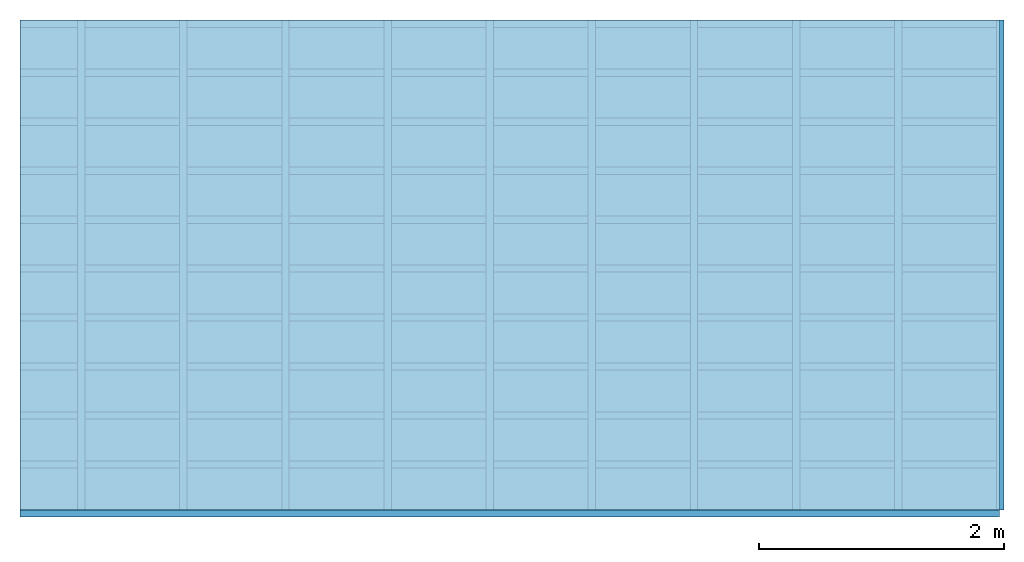
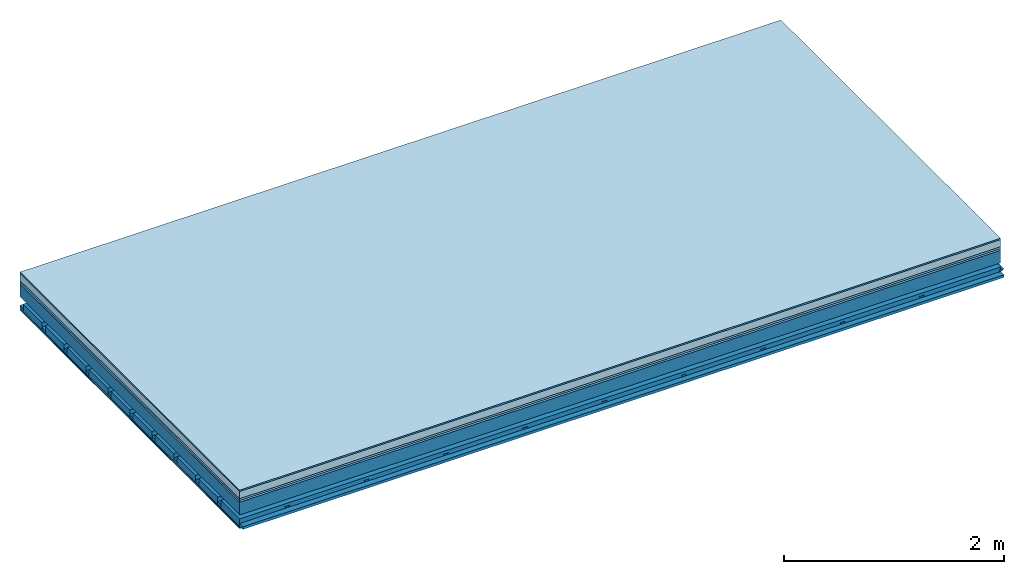
# One storey: 7 plates, 4 members, 1 element without a shape of its own.
"""IFC4 building model written with IfcOpenShell, lengths in metres."""

from ifc_helpers import new_model, si_unit, derived_unit, direction, frame, frame_2d, origin, origin_with_axes, place, context, project, spatial, polyline, rectangle, outline, extrude, material, layer, layer_set, type_object, element, aggregate, save


model = new_model("IFC4")

# Units and contexts
plan_context = context("Plan", 3, precision=1e-05, world=origin(), true_north=direction((0.0, 1.0)))
model_context = context("Model", 3, precision=1e-05, world=origin(), true_north=direction((0.0, 1.0)))
ifc_project = project(units=[si_unit("LENGTHUNIT", "METRE"), derived_unit("SOUNDPRESSUREUNIT", [(si_unit("PRESSUREUNIT", "PASCAL", prefix="MICRO"), 0)]), si_unit("ENERGYUNIT", "JOULE", prefix="MEGA"), si_unit("MASSUNIT", "GRAM", prefix="KILO"), derived_unit("THERMALTRANSMITTANCEUNIT", [(si_unit("POWERUNIT", "WATT"), 1), (si_unit("AREAUNIT", "SQUARE_METRE"), -1), (si_unit("THERMODYNAMICTEMPERATUREUNIT", "KELVIN"), -1)]), derived_unit("AREADENSITYUNIT", [(si_unit("MASSUNIT", "GRAM", prefix="KILO"), 1), (si_unit("AREAUNIT", "SQUARE_METRE"), -1)]), derived_unit("USERDEFINED", [(si_unit("ENERGYUNIT", "JOULE", prefix="MEGA"), 1), (si_unit("AREAUNIT", "SQUARE_METRE"), -1)])], contexts=[plan_context, model_context])

# Site, building, storey
site = spatial("IfcSite", under=ifc_project)
building_placement = place(None, origin())
building = spatial("IfcBuilding", under=site, at=building_placement)
storey_placement = place(building_placement, origin())
storey = spatial("IfcBuildingStorey", under=building, at=storey_placement)

# Slab, members, plates
ifc_material_1 = material(Category="11.013")
ifc_layer_1 = layer(ifc_material_1, 0.015, Name="Flooring")
ifc_material_2 = material(Name="Cement screed", Category="04.006")
ifc_layer_2 = layer(ifc_material_2, 0.08, Name="On-material")
ifc_material_3 = material(Name="Wood fiber generic product", Category="10.009")
ifc_layer_3 = layer(ifc_material_3, 0.02, Name="Impact sound insulation")
ifc_material_4 = material(Category="10.004")
ifc_layer_4 = layer(ifc_material_4, 0.02, Name="Additional insulation")
ifc_material_5 = material(Name="no composite action")
ifc_layer_5 = layer(ifc_material_5, 0.0, Name="Bond")
ifc_layer_6 = layer(None, 0.14, Name="Supporting structure")
ifc_layer_7 = layer(ifc_material_5, 0.0, Name="Bond")
ifc_layer_8 = layer(None, 0.095, Name="Coupling")
ifc_layer_9 = layer(None, 0.03, Name="Battens / profiles")
ifc_material_6 = material(Name="Plasterboard type A", Category="03.008")
ifc_layer_10 = layer(ifc_material_6, 0.0125, Name="Ceiling covering 1st layer")
ifc_layer_11 = layer(ifc_material_6, 0.0125, Name="Ceiling covering layer 2")
ifc_material_7 = material(Category="04.001")
ifc_layer_12 = layer(ifc_material_7, 0.003, Name="Surface / treatment")
ifc_layer_set = layer_set([ifc_layer_1, ifc_layer_2, ifc_layer_3, ifc_layer_4, ifc_layer_5, ifc_layer_6, ifc_layer_7, ifc_layer_8, ifc_layer_9, ifc_layer_10, ifc_layer_11, ifc_layer_12])
slab_type = type_object("IfcSlabType", Name="A2151", PredefinedType="NOTDEFINED", material=ifc_layer_set)
slab_placement = place(None, frame((0.0, 0.0, 0.0), z_axis=(0.0, 0.0, -1.0), x_axis=(1.0, 0.0, 0.0)))
slab = element("IfcSlab", 1, at=slab_placement, inside=storey, type_object=slab_type, material=ifc_layer_set, Name="Slab #1")
ifc_material_8 = material(Name="Solid timber panel")
member_1_placement = place(slab_placement, origin())
member_1 = element("IfcMember", 2, at=member_1_placement, material=ifc_material_8, Name="Supporting structure", context=plan_context, shape_type="SweptSolid", body=[
    extrude(rectangle(XDim=1.0, YDim=0.14, at=frame_2d((0.5, 0.07), x_axis=(1.0, 0.0))), frame((0.0, 4.0, 0.135), z_axis=(0.0, -1.0, 0.0), x_axis=(1.0, 0.0, 0.0)), (0.0, 0.0, 1.0), 4.0),
    extrude(rectangle(XDim=1.0, YDim=0.14, at=frame_2d((0.5, 0.07), x_axis=(1.0, 0.0))), frame((1.0, 4.0, 0.135), z_axis=(0.0, -1.0, 0.0), x_axis=(1.0, 0.0, 0.0)), (0.0, 0.0, 1.0), 4.0),
    extrude(rectangle(XDim=1.0, YDim=0.14, at=frame_2d((0.5, 0.07), x_axis=(1.0, 0.0))), frame((2.0, 4.0, 0.135), z_axis=(0.0, -1.0, 0.0), x_axis=(1.0, 0.0, 0.0)), (0.0, 0.0, 1.0), 4.0),
    extrude(rectangle(XDim=1.0, YDim=0.14, at=frame_2d((0.5, 0.07), x_axis=(1.0, 0.0))), frame((3.0, 4.0, 0.135), z_axis=(0.0, -1.0, 0.0), x_axis=(1.0, 0.0, 0.0)), (0.0, 0.0, 1.0), 4.0),
    extrude(rectangle(XDim=1.0, YDim=0.14, at=frame_2d((0.5, 0.07), x_axis=(1.0, 0.0))), frame((4.0, 4.0, 0.135), z_axis=(0.0, -1.0, 0.0), x_axis=(1.0, 0.0, 0.0)), (0.0, 0.0, 1.0), 4.0),
    extrude(rectangle(XDim=1.0, YDim=0.14, at=frame_2d((0.5, 0.07), x_axis=(1.0, 0.0))), frame((5.0, 4.0, 0.135), z_axis=(0.0, -1.0, 0.0), x_axis=(1.0, 0.0, 0.0)), (0.0, 0.0, 1.0), 4.0),
    extrude(rectangle(XDim=1.0, YDim=0.14, at=frame_2d((0.5, 0.07), x_axis=(1.0, 0.0))), frame((6.0, 4.0, 0.135), z_axis=(0.0, -1.0, 0.0), x_axis=(1.0, 0.0, 0.0)), (0.0, 0.0, 1.0), 4.0),
    extrude(rectangle(XDim=1.0, YDim=0.14, at=frame_2d((0.5, 0.07), x_axis=(1.0, 0.0))), frame((7.0, 4.0, 0.135), z_axis=(0.0, -1.0, 0.0), x_axis=(1.0, 0.0, 0.0)), (0.0, 0.0, 1.0), 4.0),
])
ifc_material_9 = material()
member_2_placement = place(slab_placement, origin())
member_2 = element("IfcMember", 3, at=member_2_placement, material=ifc_material_9, Name="Coupling", context=plan_context, shape_type="SweptSolid", body=[
    extrude(outline(polyline([(0.0, 0.0), (0.06, 0.0), (0.04, 0.02), (0.02, 0.02), (0.0, 0.0)])), frame((0.47, 4.0, 0.35), z_axis=(0.0, -1.0, 0.0), x_axis=(1.0, 0.0, 0.0)), (0.0, 0.0, 1.0), 4.0),
    extrude(outline(polyline([(0.0, 0.0), (0.06, 0.0), (0.04, 0.02), (0.02, 0.02), (0.0, 0.0)])), frame((1.304, 4.0, 0.35), z_axis=(0.0, -1.0, 0.0), x_axis=(1.0, 0.0, 0.0)), (0.0, 0.0, 1.0), 4.0),
    extrude(outline(polyline([(0.0, 0.0), (0.06, 0.0), (0.04, 0.02), (0.02, 0.02), (0.0, 0.0)])), frame((2.138, 4.0, 0.35), z_axis=(0.0, -1.0, 0.0), x_axis=(1.0, 0.0, 0.0)), (0.0, 0.0, 1.0), 4.0),
    extrude(outline(polyline([(0.0, 0.0), (0.06, 0.0), (0.04, 0.02), (0.02, 0.02), (0.0, 0.0)])), frame((2.972, 4.0, 0.35), z_axis=(0.0, -1.0, 0.0), x_axis=(1.0, 0.0, 0.0)), (0.0, 0.0, 1.0), 4.0),
    extrude(outline(polyline([(0.0, 0.0), (0.06, 0.0), (0.04, 0.02), (0.02, 0.02), (0.0, 0.0)])), frame((3.806, 4.0, 0.35), z_axis=(0.0, -1.0, 0.0), x_axis=(1.0, 0.0, 0.0)), (0.0, 0.0, 1.0), 4.0),
    extrude(outline(polyline([(0.0, 0.0), (0.06, 0.0), (0.04, 0.02), (0.02, 0.02), (0.0, 0.0)])), frame((4.64, 4.0, 0.35), z_axis=(0.0, -1.0, 0.0), x_axis=(1.0, 0.0, 0.0)), (0.0, 0.0, 1.0), 4.0),
    extrude(outline(polyline([(0.0, 0.0), (0.06, 0.0), (0.04, 0.02), (0.02, 0.02), (0.0, 0.0)])), frame((5.474, 4.0, 0.35), z_axis=(0.0, -1.0, 0.0), x_axis=(1.0, 0.0, 0.0)), (0.0, 0.0, 1.0), 4.0),
    extrude(outline(polyline([(0.0, 0.0), (0.06, 0.0), (0.04, 0.02), (0.02, 0.02), (0.0, 0.0)])), frame((6.308, 4.0, 0.35), z_axis=(0.0, -1.0, 0.0), x_axis=(1.0, 0.0, 0.0)), (0.0, 0.0, 1.0), 4.0),
    extrude(outline(polyline([(0.0, 0.0), (0.06, 0.0), (0.04, 0.02), (0.02, 0.02), (0.0, 0.0)])), frame((7.142, 4.0, 0.35), z_axis=(0.0, -1.0, 0.0), x_axis=(1.0, 0.0, 0.0)), (0.0, 0.0, 1.0), 4.0),
    extrude(outline(polyline([(0.0, 0.0), (0.06, 0.0), (0.04, 0.02), (0.02, 0.02), (0.0, 0.0)])), frame((7.976, 4.0, 0.35), z_axis=(0.0, -1.0, 0.0), x_axis=(1.0, 0.0, 0.0)), (0.0, 0.0, 1.0), 4.0),
])
member_3_placement = place(slab_placement, origin())
member_3 = element("IfcMember", 4, at=member_3_placement, material=ifc_material_9, Name="Battens / profiles", context=plan_context, shape_type="SweptSolid", body=[
    extrude(rectangle(XDim=0.06, YDim=0.03, at=frame_2d((0.03, 0.015), x_axis=(1.0, 0.0))), frame((0.0, 0.0, 0.37), z_axis=(1.0, 0.0, 0.0), x_axis=(0.0, 1.0, 0.0)), (0.0, 0.0, 1.0), 8.0),
    extrude(rectangle(XDim=0.06, YDim=0.03, at=frame_2d((0.03, 0.015), x_axis=(1.0, 0.0))), frame((0.0, 0.4, 0.37), z_axis=(1.0, 0.0, 0.0), x_axis=(0.0, 1.0, 0.0)), (0.0, 0.0, 1.0), 8.0),
    extrude(rectangle(XDim=0.06, YDim=0.03, at=frame_2d((0.03, 0.015), x_axis=(1.0, 0.0))), frame((0.0, 0.8, 0.37), z_axis=(1.0, 0.0, 0.0), x_axis=(0.0, 1.0, 0.0)), (0.0, 0.0, 1.0), 8.0),
    extrude(rectangle(XDim=0.06, YDim=0.03, at=frame_2d((0.03, 0.015), x_axis=(1.0, 0.0))), frame((0.0, 1.2, 0.37), z_axis=(1.0, 0.0, 0.0), x_axis=(0.0, 1.0, 0.0)), (0.0, 0.0, 1.0), 8.0),
    extrude(rectangle(XDim=0.06, YDim=0.03, at=frame_2d((0.03, 0.015), x_axis=(1.0, 0.0))), frame((0.0, 1.6, 0.37), z_axis=(1.0, 0.0, 0.0), x_axis=(0.0, 1.0, 0.0)), (0.0, 0.0, 1.0), 8.0),
    extrude(rectangle(XDim=0.06, YDim=0.03, at=frame_2d((0.03, 0.015), x_axis=(1.0, 0.0))), frame((0.0, 2.0, 0.37), z_axis=(1.0, 0.0, 0.0), x_axis=(0.0, 1.0, 0.0)), (0.0, 0.0, 1.0), 8.0),
    extrude(rectangle(XDim=0.06, YDim=0.03, at=frame_2d((0.03, 0.015), x_axis=(1.0, 0.0))), frame((0.0, 2.4, 0.37), z_axis=(1.0, 0.0, 0.0), x_axis=(0.0, 1.0, 0.0)), (0.0, 0.0, 1.0), 8.0),
    extrude(rectangle(XDim=0.06, YDim=0.03, at=frame_2d((0.03, 0.015), x_axis=(1.0, 0.0))), frame((0.0, 2.8, 0.37), z_axis=(1.0, 0.0, 0.0), x_axis=(0.0, 1.0, 0.0)), (0.0, 0.0, 1.0), 8.0),
    extrude(rectangle(XDim=0.06, YDim=0.03, at=frame_2d((0.03, 0.015), x_axis=(1.0, 0.0))), frame((0.0, 3.2, 0.37), z_axis=(1.0, 0.0, 0.0), x_axis=(0.0, 1.0, 0.0)), (0.0, 0.0, 1.0), 8.0),
    extrude(rectangle(XDim=0.06, YDim=0.03, at=frame_2d((0.03, 0.015), x_axis=(1.0, 0.0))), frame((0.0, 3.6, 0.37), z_axis=(1.0, 0.0, 0.0), x_axis=(0.0, 1.0, 0.0)), (0.0, 0.0, 1.0), 8.0),
    extrude(rectangle(XDim=0.06, YDim=0.03, at=frame_2d((0.03, 0.015), x_axis=(1.0, 0.0))), frame((0.0, 4.0, 0.37), z_axis=(1.0, 0.0, 0.0), x_axis=(0.0, 1.0, 0.0)), (0.0, 0.0, 1.0), 8.0),
])
ifc_material_10 = material()
member_4_placement = place(slab_placement, origin())
member_4 = element("IfcMember", 5, at=member_4_placement, material=ifc_material_10, Name="Cavity", context=plan_context, shape_type="SweptSolid", body=[
    extrude(rectangle(XDim=0.34, YDim=0.08, at=frame_2d((0.17, 0.04), x_axis=(1.0, 0.0))), frame((0.0, 0.06, 0.32), z_axis=(1.0, 0.0, 0.0), x_axis=(0.0, 1.0, 0.0)), (0.0, 0.0, 1.0), 8.0),
    extrude(rectangle(XDim=0.34, YDim=0.08, at=frame_2d((0.17, 0.04), x_axis=(1.0, 0.0))), frame((0.0, 0.46, 0.32), z_axis=(1.0, 0.0, 0.0), x_axis=(0.0, 1.0, 0.0)), (0.0, 0.0, 1.0), 8.0),
    extrude(rectangle(XDim=0.34, YDim=0.08, at=frame_2d((0.17, 0.04), x_axis=(1.0, 0.0))), frame((0.0, 0.86, 0.32), z_axis=(1.0, 0.0, 0.0), x_axis=(0.0, 1.0, 0.0)), (0.0, 0.0, 1.0), 8.0),
    extrude(rectangle(XDim=0.34, YDim=0.08, at=frame_2d((0.17, 0.04), x_axis=(1.0, 0.0))), frame((0.0, 1.26, 0.32), z_axis=(1.0, 0.0, 0.0), x_axis=(0.0, 1.0, 0.0)), (0.0, 0.0, 1.0), 8.0),
    extrude(rectangle(XDim=0.34, YDim=0.08, at=frame_2d((0.17, 0.04), x_axis=(1.0, 0.0))), frame((0.0, 1.66, 0.32), z_axis=(1.0, 0.0, 0.0), x_axis=(0.0, 1.0, 0.0)), (0.0, 0.0, 1.0), 8.0),
    extrude(rectangle(XDim=0.34, YDim=0.08, at=frame_2d((0.17, 0.04), x_axis=(1.0, 0.0))), frame((0.0, 2.06, 0.32), z_axis=(1.0, 0.0, 0.0), x_axis=(0.0, 1.0, 0.0)), (0.0, 0.0, 1.0), 8.0),
    extrude(rectangle(XDim=0.34, YDim=0.08, at=frame_2d((0.17, 0.04), x_axis=(1.0, 0.0))), frame((0.0, 2.46, 0.32), z_axis=(1.0, 0.0, 0.0), x_axis=(0.0, 1.0, 0.0)), (0.0, 0.0, 1.0), 8.0),
    extrude(rectangle(XDim=0.34, YDim=0.08, at=frame_2d((0.17, 0.04), x_axis=(1.0, 0.0))), frame((0.0, 2.86, 0.32), z_axis=(1.0, 0.0, 0.0), x_axis=(0.0, 1.0, 0.0)), (0.0, 0.0, 1.0), 8.0),
    extrude(rectangle(XDim=0.34, YDim=0.08, at=frame_2d((0.17, 0.04), x_axis=(1.0, 0.0))), frame((0.0, 3.26, 0.32), z_axis=(1.0, 0.0, 0.0), x_axis=(0.0, 1.0, 0.0)), (0.0, 0.0, 1.0), 8.0),
    extrude(rectangle(XDim=0.34, YDim=0.08, at=frame_2d((0.17, 0.04), x_axis=(1.0, 0.0))), frame((0.0, 3.66, 0.32), z_axis=(1.0, 0.0, 0.0), x_axis=(0.0, 1.0, 0.0)), (0.0, 0.0, 1.0), 8.0),
])
plate_1_placement = place(slab_placement, origin())
plate_1 = element("IfcPlate", 6, at=plate_1_placement, material=ifc_material_1, Name="Flooring", context=plan_context, shape_type="SweptSolid", body=[
    extrude(rectangle(XDim=8.0, YDim=4.0, at=frame_2d((4.0, 2.0), x_axis=(1.0, 0.0))), origin_with_axes(), (0.0, 0.0, 1.0), 0.015),
])
plate_2_placement = place(slab_placement, origin())
plate_2 = element("IfcPlate", 7, at=plate_2_placement, material=ifc_material_2, Name="On-material", context=plan_context, shape_type="SweptSolid", body=[
    extrude(rectangle(XDim=8.0, YDim=4.0, at=frame_2d((4.0, 2.0), x_axis=(1.0, 0.0))), frame((0.0, 0.0, 0.015), z_axis=(0.0, 0.0, 1.0), x_axis=(1.0, 0.0, 0.0)), (0.0, 0.0, 1.0), 0.08),
])
plate_3_placement = place(slab_placement, origin())
plate_3 = element("IfcPlate", 8, at=plate_3_placement, material=ifc_material_3, Name="Impact sound insulation", context=plan_context, shape_type="SweptSolid", body=[
    extrude(rectangle(XDim=8.0, YDim=4.0, at=frame_2d((4.0, 2.0), x_axis=(1.0, 0.0))), frame((0.0, 0.0, 0.095), z_axis=(0.0, 0.0, 1.0), x_axis=(1.0, 0.0, 0.0)), (0.0, 0.0, 1.0), 0.02),
])
plate_4_placement = place(slab_placement, origin())
plate_4 = element("IfcPlate", 9, at=plate_4_placement, material=ifc_material_4, Name="Additional insulation", context=plan_context, shape_type="SweptSolid", body=[
    extrude(rectangle(XDim=8.0, YDim=4.0, at=frame_2d((4.0, 2.0), x_axis=(1.0, 0.0))), frame((0.0, 0.0, 0.115), z_axis=(0.0, 0.0, 1.0), x_axis=(1.0, 0.0, 0.0)), (0.0, 0.0, 1.0), 0.02),
])
plate_5_placement = place(slab_placement, origin())
plate_5 = element("IfcPlate", 10, at=plate_5_placement, material=ifc_material_6, Name="Ceiling covering 1st layer", context=plan_context, shape_type="SweptSolid", body=[
    extrude(rectangle(XDim=8.0, YDim=4.0, at=frame_2d((4.0, 2.0), x_axis=(1.0, 0.0))), frame((0.0, 0.0, 0.4), z_axis=(0.0, 0.0, 1.0), x_axis=(1.0, 0.0, 0.0)), (0.0, 0.0, 1.0), 0.0125),
])
plate_6_placement = place(slab_placement, origin())
plate_6 = element("IfcPlate", 11, at=plate_6_placement, material=ifc_material_6, Name="Ceiling covering layer 2", context=plan_context, shape_type="SweptSolid", body=[
    extrude(rectangle(XDim=8.0, YDim=4.0, at=frame_2d((4.0, 2.0), x_axis=(1.0, 0.0))), frame((0.0, 0.0, 0.4125), z_axis=(0.0, 0.0, 1.0), x_axis=(1.0, 0.0, 0.0)), (0.0, 0.0, 1.0), 0.0125),
])
plate_7_placement = place(slab_placement, origin())
plate_7 = element("IfcPlate", 12, at=plate_7_placement, material=ifc_material_7, Name="Surface / treatment", context=plan_context, shape_type="SweptSolid", body=[
    extrude(rectangle(XDim=8.0, YDim=4.0, at=frame_2d((4.0, 2.0), x_axis=(1.0, 0.0))), frame((0.0, 0.0, 0.425), z_axis=(0.0, 0.0, 1.0), x_axis=(1.0, 0.0, 0.0)), (0.0, 0.0, 1.0), 0.003),
])
aggregate(slab, [plate_1, plate_2, plate_3, plate_4, member_1, member_2, member_3, member_4, plate_5, plate_6, plate_7])

save(model, "model.ifc")
